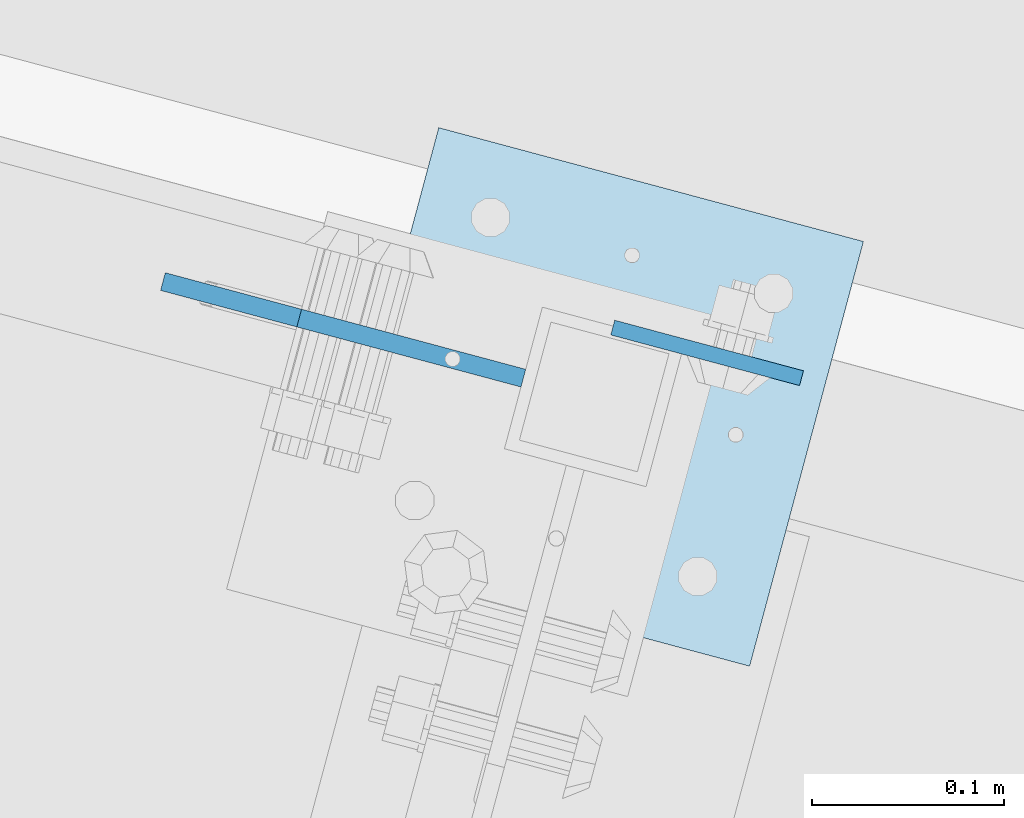
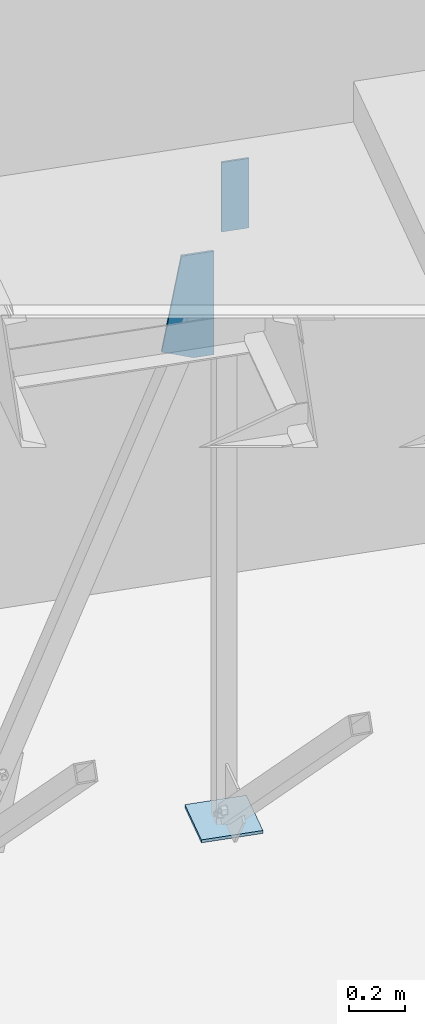
# One storey, part 1698 of 1763: 3 plates, 2 elements without a shape of their own.
"""IFC2X3 building model written with IfcOpenShell, lengths in millimetres."""

from ifc_helpers import new_model, si_unit, frame, origin_with_axes, place, context, subcontext, project, spatial, faceted_brep, material, type_object, element, aggregate, save


model = new_model("IFC2X3")

# Units and contexts
model_context = context("Model", 3, precision=1e-05, world=origin_with_axes())
body_context = subcontext(model_context, "Body", "Model", "MODEL_VIEW")
ifc_project = project(units=[si_unit("LENGTHUNIT", "METRE", prefix="MILLI"), si_unit("AREAUNIT", "SQUARE_METRE"), si_unit("VOLUMEUNIT", "CUBIC_METRE"), si_unit("MASSUNIT", "GRAM", prefix="KILO"), si_unit("TIMEUNIT", "SECOND"), si_unit("PLANEANGLEUNIT", "RADIAN"), si_unit("SOLIDANGLEUNIT", "STERADIAN"), si_unit("THERMODYNAMICTEMPERATUREUNIT", "DEGREE_CELSIUS"), si_unit("LUMINOUSINTENSITYUNIT", "LUMEN")], contexts=[model_context])

# Site, building, storey
site_placement = place(None, origin_with_axes())
site = spatial("IfcSite", under=ifc_project, at=site_placement, CompositionType="ELEMENT")
building_placement = place(site_placement, origin_with_axes())
building = spatial("IfcBuilding", under=site, at=building_placement, Name="Undefined", CompositionType="ELEMENT")
storey_placement = place(building_placement, origin_with_axes())
storey = spatial("IfcBuildingStorey", under=building, at=storey_placement, Name="Undefined", CompositionType="ELEMENT", Elevation=0.0)

# Assembly, plate
assembly_1_placement = place(storey_placement, origin_with_axes())
assembly_1 = element("IfcElementAssembly", 1, at=assembly_1_placement, inside=storey, Name="FRAME", AssemblyPlace="NOTDEFINED", PredefinedType="RIGID_FRAME")
ifc_material = material(Name="STEEL/A36")
plate_type_1 = type_object("IfcPlateType", PredefinedType="NOTDEFINED")
plate_1_placement = place(assembly_1_placement, frame((-26665.6090630306, 63034.3624357233, 2590.80000024992), z_axis=(0.965913267114843, -0.258865912030785, 0.0), x_axis=(0.0, 0.0, -1.0)))
plate_1 = element("IfcPlate", 2, at=plate_1_placement, type_object=plate_type_1, material=ifc_material, Name="PLATE", context=body_context, shape_type="Brep", body=[
    faceted_brep([(0.0, -3.96900000000096, 0.0), (-1.18234311230481e-11, -3.96900000000096, 101.599998474121), (-1.18234311230481e-11, 3.96900000000096, 101.599998474121), (0.0, 3.96900000000096, 0.0), (304.799987792969, -3.96900000000096, 101.599998474121), (304.799987792969, 3.96900000000096, 101.599998474121), (304.799987792969, -3.96900000000096, -3.63797880709171e-11), (304.799987792969, 3.96900000000096, -3.63797880709171e-11)], [[[0, 1, 2, 3]], [[1, 4, 5, 2]], [[4, 6, 7, 5]], [[6, 0, 3, 7]], [[5, 7, 3, 2]], [[6, 4, 1, 0]]]),
])
aggregate(assembly_1, [plate_1])

# Assembly, plates
assembly_2_placement = place(storey_placement, origin_with_axes())
assembly_2 = element("IfcElementAssembly", 3, at=assembly_2_placement, inside=storey, Name="COLUMN", AssemblyPlace="NOTDEFINED", PredefinedType="RIGID_FRAME")
plate_type_2 = type_object("IfcPlateType", PredefinedType="NOTDEFINED")
plate_2_placement = place(assembly_2_placement, frame((-26815.2457103822, 62917.4837524643, -260.349999999997), z_axis=(0.258819045079128, 0.965925826295336, 0.0), x_axis=(0.965925826295336, -0.25881904507913, 0.0)))
plate_2 = element("IfcPlate", 4, at=plate_2_placement, type_object=plate_type_2, material=ifc_material, Name="PLATE", context=body_context, shape_type="Brep", body=[
    faceted_brep([(0.0, -6.34999999999491, 1.45519152283669e-11), (0.0, -6.35000000001855, 228.600006104178), (0.0, 6.34999999996944, 228.600006104134), (0.0, 6.34999999999491, -2.91038304567337e-11), (228.600006103363, -6.34999999999999, 228.600006104673), (228.600006103363, 6.35000000000002, 228.600006104673), (228.600006103565, -6.34999999936554, -7.49423634260893e-10), (228.600006103557, 6.35000000064611, -7.13043846189976e-10)], [[[0, 1, 2, 3]], [[1, 4, 5, 2]], [[4, 6, 7, 5]], [[6, 0, 3, 7]], [[5, 7, 3, 2]], [[6, 4, 1, 0]]]),
])
plate_type_3 = type_object("IfcPlateType", PredefinedType="NOTDEFINED")
plate_3_placement = place(assembly_2_placement, frame((-26712.085762984, 63008.0677256177, 2235.20000008304), z_axis=(-0.965913267114846, 0.258865912030774, 0.0), x_axis=(0.0, 0.0, -1.0)))
plate_3 = element("IfcPlate", 5, at=plate_3_placement, type_object=plate_type_3, material=ifc_material, Name="PLATE", context=body_context, shape_type="Brep", body=[
    faceted_brep([(0.0, -4.76249999999982, 0.0), (3.8198777474463e-11, -4.76249999978609, 120.649999999834), (3.45607986673713e-11, 4.76250000024447, 120.649999999841), (0.0, 4.76249999999982, 0.0), (406.560302734375, -4.76249999963329, 194.001922607138), (406.560302734375, 4.76250000039727, 194.001922607145), (452.793731689453, -4.76249999986612, 75.7163848875789), (452.793731689453, 4.76250000016444, 75.7163848875862), (452.793731689453, -4.76250000001164, -5.82076609134674e-11), (452.793731689453, 4.76250000001164, -5.0931703299284e-11)], [[[0, 1, 2, 3]], [[1, 4, 5, 2]], [[4, 6, 7, 5]], [[6, 8, 9, 7]], [[8, 0, 3, 9]], [[5, 7, 9, 3, 2]], [[8, 6, 4, 1, 0]]]),
])
aggregate(assembly_2, [plate_3, plate_2])

save(model, "model.ifc")
